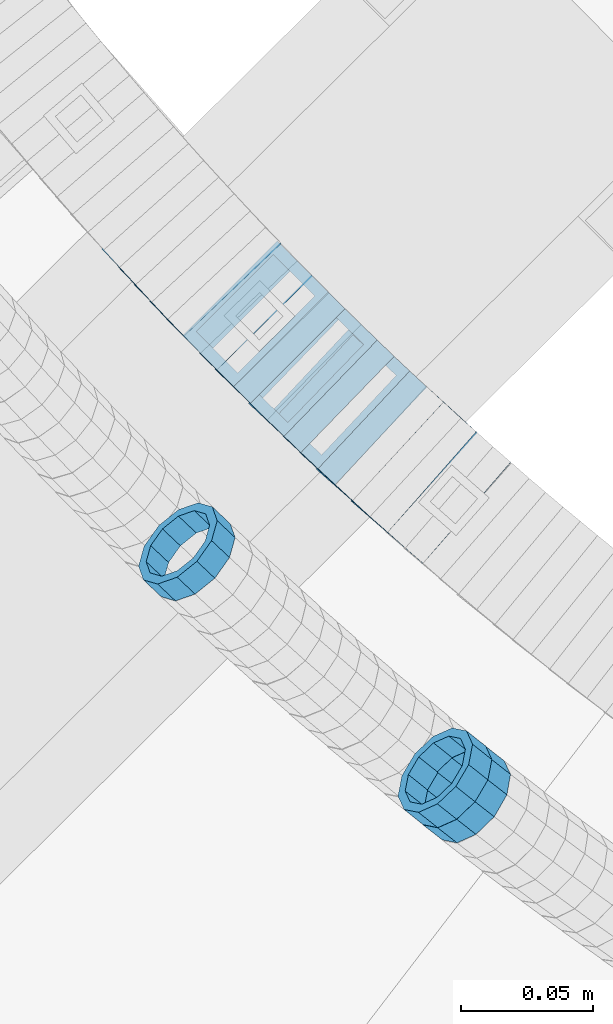
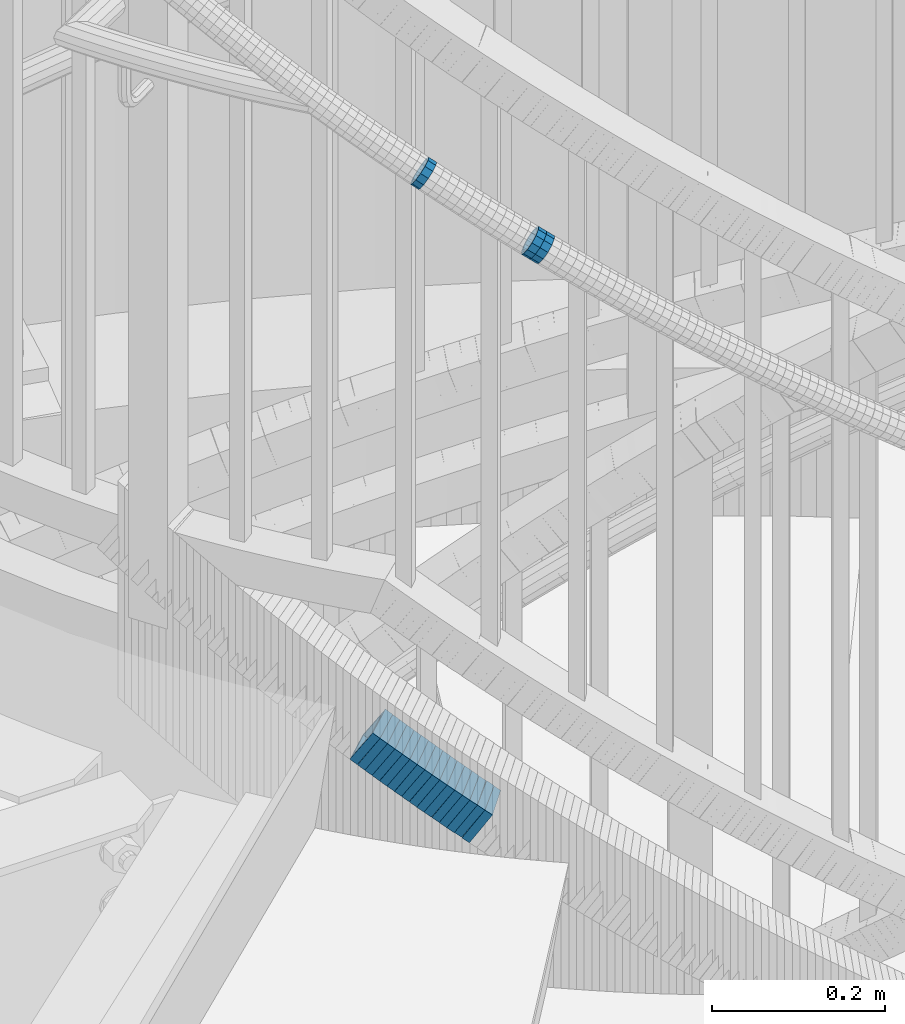
# One storey, part 731 of 975: 19 members.
"""IFC2X3 building model written with IfcOpenShell, lengths in millimetres."""

import ifcopenshell
import ifcopenshell.guid

model = None  # the IFC model being written
_history = None  # IfcOwnerHistory: only IFC2X3 demands one
_inside = {}  # id of a spatial element -> (the spatial element, [elements in it])
_under = {}  # id of a project, library or spatial element -> (it, [spatial elements below it])
_declared = {}  # id of a project -> (the project, [libraries it declares])
_typed = {}  # id of a type object -> (the type object, [elements of that type])
_made_of = {}  # id of a material, layer set ... -> (it, [elements and type objects made of it])


def new_model(schema):
    """Start an empty IFC model of exactly this schema.

    Asked for "IFC4X3", IfcOpenShell would pick the latest addendum, in which some entities
    have other attributes; the version numbers below select the first issue.
    IFC2X3 requires an IfcOwnerHistory on every rooted entity: one is made here for all.
    """
    global model, _history
    if schema == "IFC4X3":
        model = ifcopenshell.file(schema_version=(4, 3, 0, 0))
    else:
        model = ifcopenshell.file(schema=schema)
    _inside.clear()
    _under.clear()
    _declared.clear()
    _typed.clear()
    _made_of.clear()
    _history = None
    if model.schema == "IFC2X3":
        org = make("IfcOrganization", Name="unknown")
        user = make(
            "IfcPersonAndOrganization",
            ThePerson=make("IfcPerson", FamilyName="unknown"),
            TheOrganization=org,
        )
        app = make(
            "IfcApplication",
            ApplicationDeveloper=org,
            Version="unknown",
            ApplicationFullName="unknown",
            ApplicationIdentifier="unknown",
        )
        _history = make(
            "IfcOwnerHistory",
            OwningUser=user,
            OwningApplication=app,
            ChangeAction="ADDED",
            CreationDate=0,
        )
    return model


def make(cls, **values):
    """One entity of the class cls with the attributes given. An attribute that is None is left unset."""
    return model.create_entity(
        cls, **{name: value for name, value in values.items() if value is not None}
    )


def rooted(cls, **values):
    """An entity with a GlobalId (a new one), such as an element, a storey or a relation."""
    return make(cls, GlobalId=ifcopenshell.guid.new(), OwnerHistory=_history, **values)


def si_unit(unit_type, name, prefix=None):
    """IfcSIUnit, for example si_unit("LENGTHUNIT", "METRE", prefix="MILLI")."""
    return make("IfcSIUnit", UnitType=unit_type, Prefix=prefix, Name=name)


def assignment(units):
    """IfcUnitAssignment: the units of a project."""
    return None if units is None else make("IfcUnitAssignment", Units=units)


def point(xyz):
    """IfcCartesianPoint."""
    return None if xyz is None else make("IfcCartesianPoint", Coordinates=xyz)


def direction(xyz):
    """IfcDirection."""
    return None if xyz is None else make("IfcDirection", DirectionRatios=xyz)


def frame(location, z_axis=None, x_axis=None):
    """IfcAxis2Placement3D, a coordinate frame: its origin and axes. An axis left out is left unset."""
    return make(
        "IfcAxis2Placement3D",
        Location=point(location),
        Axis=direction(z_axis),
        RefDirection=direction(x_axis),
    )


def origin_with_axes():
    """The frame at (0, 0, 0) with the z axis (0, 0, 1) and the x axis (1, 0, 0) written out."""
    return frame((0.0, 0.0, 0.0), z_axis=(0.0, 0.0, 1.0), x_axis=(1.0, 0.0, 0.0))


def place(relative_to, where):
    """IfcLocalPlacement: puts the frame where relative to a parent placement (None: the world)."""
    return make(
        "IfcLocalPlacement", PlacementRelTo=relative_to, RelativePlacement=where
    )


def context(
    kind, dimensions, precision=None, world=None, true_north=None, identifier=None
):
    """IfcGeometricRepresentationContext, for example the 3D "Model" context."""
    return make(
        "IfcGeometricRepresentationContext",
        ContextIdentifier=identifier,
        ContextType=kind,
        CoordinateSpaceDimension=dimensions,
        Precision=precision,
        WorldCoordinateSystem=world,
        TrueNorth=true_north,
    )


def subcontext(parent, identifier, kind, view, scale=None):
    """IfcGeometricRepresentationSubContext, for example "Body" below "Model"."""
    return make(
        "IfcGeometricRepresentationSubContext",
        ContextIdentifier=identifier,
        ContextType=kind,
        ParentContext=parent,
        TargetScale=scale,
        TargetView=view,
    )


def project(units=None, contexts=None):
    """IfcProject with its units and contexts."""
    return rooted(
        "IfcProject",
        Name="project",
        RepresentationContexts=contexts,
        UnitsInContext=assignment(units),
    )


def spatial(cls, under=None, at=None, **own):
    """A site, building, storey or space (cls), placed at a placement, below another one or the project."""
    s = rooted(cls, ObjectPlacement=at, **own)
    if under is not None:
        _under.setdefault(under.id(), (under, []))[1].append(s)
    return s


def faces_of(points, faces, orient=None, outer=None):
    """IfcFace entities. A face is a list of loops; a loop is a list of indices into points, from 0.

    orient and outer hold one flag for each loop. By default every Orientation is true, the
    first loop of a face is its IfcFaceOuterBound and the others are IfcFaceBound.
    """
    made = []
    for i, loops in enumerate(faces):
        bounds = []
        for j, loop in enumerate(loops):
            is_outer = j == 0 if outer is None else outer[i][j]
            bounds.append(
                make(
                    "IfcFaceOuterBound" if is_outer else "IfcFaceBound",
                    Bound=make("IfcPolyLoop", Polygon=[points[k] for k in loop]),
                    Orientation=True if orient is None else orient[i][j],
                )
            )
        made.append(make("IfcFace", Bounds=bounds))
    return made


def faceted_brep(points, faces, orient=None, outer=None, voids=None):
    """IfcFacetedBrep: a solid bounded by flat faces; with voids (closed shells), ...WithVoids."""
    shared = [point(p) for p in points]
    hull = make("IfcClosedShell", CfsFaces=faces_of(shared, faces, orient, outer))
    if voids is None:
        return make("IfcFacetedBrep", Outer=hull)
    return make(
        "IfcFacetedBrepWithVoids",
        Outer=hull,
        Voids=[
            make(cls, CfsFaces=faces_of(shared, fs, o, b)) for cls, fs, o, b in voids
        ],
    )


def shape(context_of_items, identifier, shape_type, items):
    """IfcShapeRepresentation: the items that make up one representation, for example the "Body"."""
    return make(
        "IfcShapeRepresentation",
        ContextOfItems=context_of_items,
        RepresentationIdentifier=identifier,
        RepresentationType=shape_type,
        Items=items,
    )


def material(Name=None, Category=None):
    """IfcMaterial."""
    return make("IfcMaterial", Name=Name, Category=Category)


def made_of(thing, what):
    """Note that an element or type object is made of a material, layer set ...; save() writes the relation."""
    if what is not None:
        _made_of.setdefault(what.id(), (what, []))[1].append(thing)
    return thing


def type_object(cls, material=None, **own):
    """A type object (cls), such as IfcWallType, which elements share."""
    return made_of(rooted(cls, **own), material)


def element(
    cls,
    number,
    at=None,
    inside=None,
    cuts=None,
    type_object=None,
    material=None,
    context=None,
    identifier="Body",
    shape_type=None,
    held_by="IfcProductDefinitionShape",
    body=None,
    shapes=None,
    **own,
):
    """One element of the class cls, such as IfcWall. Its Tag is "e" and its number.

    at: its placement. inside: the storey or other place that contains it. cuts: it is an
    opening in that element (IfcRelVoidsElement). A single representation is given by context,
    identifier, shape_type and body (its items); several are given by shapes. held_by: the class
    of the entity that holds the representations. save() writes the other relations.
    """
    e = rooted(cls, Tag="e%d" % number, ObjectPlacement=at, **own)
    if body is not None:
        shapes = [shape(context, identifier, shape_type, body)]
    if shapes is not None:
        e.Representation = make(held_by, Representations=shapes)
    if inside is not None:
        _inside.setdefault(inside.id(), (inside, []))[1].append(e)
    if cuts is not None:
        rooted(
            "IfcRelVoidsElement", RelatingBuildingElement=cuts, RelatedOpeningElement=e
        )
    if type_object is not None:
        _typed.setdefault(type_object.id(), (type_object, []))[1].append(e)
    return made_of(e, material)


def aggregate(whole, parts):
    """IfcRelAggregates: a whole, such as a stair, and the parts it consists of."""
    return rooted("IfcRelAggregates", RelatingObject=whole, RelatedObjects=parts)


def save(model, path):
    """Write the relations noted so far, then the file.

    IfcRelAggregates (storeys below a building ...), IfcRelContainedInSpatialStructure (elements
    in a storey), IfcRelDefinesByType, IfcRelAssociatesMaterial and IfcRelDeclares: one each for
    every whole, place, type object, material and project.
    """
    for whole, parts in _under.values():
        aggregate(whole, parts)
    for where, things in _inside.values():
        rooted(
            "IfcRelContainedInSpatialStructure",
            RelatedElements=things,
            RelatingStructure=where,
        )
    for kind, things in _typed.values():
        rooted("IfcRelDefinesByType", RelatedObjects=things, RelatingType=kind)
    for what, things in _made_of.values():
        rooted("IfcRelAssociatesMaterial", RelatedObjects=things, RelatingMaterial=what)
    for by, libraries in _declared.values():
        rooted("IfcRelDeclares", RelatingContext=by, RelatedDefinitions=libraries)
    model.write(path)


model = new_model("IFC2X3")

# Units and contexts
model_context = context("Model", 3, precision=1e-05, world=origin_with_axes())
body_context = subcontext(model_context, "Body", "Model", "MODEL_VIEW")
ifc_project = project(units=[si_unit("LENGTHUNIT", "METRE", prefix="MILLI"), si_unit("AREAUNIT", "SQUARE_METRE"), si_unit("VOLUMEUNIT", "CUBIC_METRE"), si_unit("MASSUNIT", "GRAM", prefix="KILO"), si_unit("TIMEUNIT", "SECOND"), si_unit("PLANEANGLEUNIT", "RADIAN"), si_unit("SOLIDANGLEUNIT", "STERADIAN"), si_unit("THERMODYNAMICTEMPERATUREUNIT", "DEGREE_CELSIUS"), si_unit("LUMINOUSINTENSITYUNIT", "LUMEN")], contexts=[model_context])

# Site, building, storey
site_placement = place(None, origin_with_axes())
site = spatial("IfcSite", under=ifc_project, at=site_placement, CompositionType="ELEMENT")
building_placement = place(site_placement, origin_with_axes())
building = spatial("IfcBuilding", under=site, at=building_placement, Name="Undefined", CompositionType="ELEMENT")
storey_placement = place(building_placement, origin_with_axes())
storey = spatial("IfcBuildingStorey", under=building, at=storey_placement, Name="Undefined", CompositionType="ELEMENT", Elevation=0.0)

# Members
ifc_material = material()
member_type_1 = type_object("IfcMemberType", PredefinedType="NOTDEFINED")
member_1_placement = place(storey_placement, frame((33819.1274220703, 2241.12991104782, 4815.55457557854), z_axis=(-0.615434495097886, -0.788188037363934, -9.19462763704361e-11), x_axis=(-0.66801209609168, 0.521598486071463, 0.530749337072745)))
element("IfcMember", 1, at=member_1_placement, inside=storey, type_object=member_type_1, material=ifc_material, Name="WALL", context=body_context, shape_type="Brep", body=[
    faceted_brep([(-2.1246523829177e-07, -15.367000000002, 0.0), (-1.83998054126278e-07, -13.3082123799541, 7.68350000000009), (10.9334349588862, -13.3082123799722, 7.68350000000555), (10.9334349588862, -15.3670000000166, 5.45696821063757e-12), (-1.06232619145885e-07, -7.68349999999919, 13.3082123799559), (10.9334349588826, -7.68350000001737, 13.3082123799609), (-3.63797880709171e-12, 3.63797880709171e-12, 15.3670000000002), (10.9334349588862, -1.45519152283669e-11, 15.3670000000043), (1.06225343188271e-07, 7.68350000000646, 13.3082123799559), (10.9334349588898, 7.68349999998827, 13.3082123799591), (1.8399441614747e-07, 13.308212379965, 7.68350000000009), (10.9334349588898, 13.3082123799395, 7.68350000000419), (2.12461600312963e-07, 15.3670000000093, 0.0), (10.9334349588971, 15.3669999999911, 3.63797880709171e-12), (1.8399441614747e-07, 13.308212379965, -7.68350000000009), (10.9334349588935, 13.3082123799431, -7.683499999996), (1.06225343188271e-07, 7.68350000000646, -13.3082123799559), (10.9334349588971, 7.68349999998827, -13.3082123799518), (-3.63797880709171e-12, 3.63797880709171e-12, -15.3670000000002), (10.9334349588971, -1.45519152283669e-11, -15.3669999999961), (-1.06232619145885e-07, -7.68349999999919, -13.3082123799559), (10.9334349588935, -7.68350000001737, -13.3082123799509), (-1.83998054126278e-07, -13.3082123799541, -7.68350000000009), (10.9334349588898, -13.3082123799686, -7.68349999999464), (-2.63386027654633e-07, -19.0500000000029, 0.0), (-2.28097633225843e-07, -16.4977839420972, -9.52499999999964), (10.9334349588898, -16.4977839421117, -9.52499999999372), (10.9334349588898, -19.0500000000211, 5.45696821063757e-12), (-1.31691194837913e-07, -9.52500000000146, -16.4977839420935), (10.9334349588971, -9.52500000001237, -16.4977839420885), (-3.63797880709171e-12, 3.63797880709171e-12, -19.0500000000002), (10.9334349588971, -1.09139364212751e-11, -19.0499999999961), (1.31687556859106e-07, 9.52500000000509, -16.4977839420935), (10.9334349589008, 9.52499999999054, -16.4977839420894), (2.28097633225843e-07, 16.4977839421044, -9.52499999999964), (10.9334349589008, 16.4977839420826, -9.52499999999645), (2.63382389675826e-07, 19.0500000000138, 0.0), (10.9334349588898, 19.0499999999884, 3.18323145620525e-12), (2.28097633225843e-07, 16.4977839421044, 9.52499999999964), (10.9334349588935, 16.497783942079, 9.52500000000282), (1.31687556859106e-07, 9.52500000000509, 16.4977839420935), (10.9334349588826, 9.52499999998327, 16.4977839420976), (-3.63797880709171e-12, 3.63797880709171e-12, 19.0500000000002), (10.9334349588826, -1.81898940354586e-11, 19.0500000000043), (-1.31691194837913e-07, -9.52500000000146, 16.4977839420935), (10.9334349588826, -9.52500000001965, 16.4977839420994), (-2.28097633225843e-07, -16.4977839420972, 9.52499999999964), (10.9334349588826, -16.4977839421117, 9.52500000000646)], [[[0, 1, 2, 3]], [[1, 4, 5, 2]], [[4, 6, 7, 5]], [[6, 8, 9, 7]], [[8, 10, 11, 9]], [[10, 12, 13, 11]], [[12, 14, 15, 13]], [[14, 16, 17, 15]], [[16, 18, 19, 17]], [[18, 20, 21, 19]], [[20, 22, 23, 21]], [[22, 0, 3, 23]], [[24, 25, 26, 27]], [[25, 28, 29, 26]], [[28, 30, 31, 29]], [[30, 32, 33, 31]], [[32, 34, 35, 33]], [[34, 36, 37, 35]], [[36, 38, 39, 37]], [[38, 40, 41, 39]], [[40, 42, 43, 41]], [[42, 44, 45, 43]], [[44, 46, 47, 45]], [[46, 24, 27, 47]], [[29, 31, 33, 35, 37, 39, 41, 43, 45, 47, 27, 26], [5, 7, 9, 11, 13, 15, 17, 19, 21, 23, 3, 2]], [[46, 44, 42, 40, 38, 36, 34, 32, 30, 28, 25, 24], [22, 20, 18, 16, 14, 12, 10, 8, 6, 4, 1, 0]]]),
])
member_2_placement = place(storey_placement, frame((33812.0167979236, 2246.78861505206, 4821.24670998094), z_axis=(-0.622075580833786, -0.782957196614418, 6.82575773680583e-11), x_axis=(-0.668012096091596, 0.530749337072773, 0.521598486071542)))
element("IfcMember", 2, at=member_2_placement, inside=storey, type_object=member_type_1, material=ifc_material, Name="WALL", context=body_context, shape_type="Brep", body=[
    faceted_brep([(-2.1246523829177e-07, -15.367000000002, 0.0), (-1.83998054126278e-07, -13.3082123799541, 7.68350000000009), (10.9334349588862, -13.3082123799722, 7.68350000000555), (10.9334349588862, -15.3670000000166, 5.45696821063757e-12), (-1.06232619145885e-07, -7.68349999999919, 13.3082123799559), (10.9334349588826, -7.68350000001737, 13.3082123799609), (-3.63797880709171e-12, 3.63797880709171e-12, 15.3670000000002), (10.9334349588862, -1.45519152283669e-11, 15.3670000000043), (1.06225343188271e-07, 7.68350000000646, 13.3082123799559), (10.9334349588898, 7.68349999998827, 13.3082123799591), (1.8399441614747e-07, 13.308212379965, 7.68350000000009), (10.9334349588898, 13.3082123799395, 7.68350000000419), (2.12461600312963e-07, 15.3670000000093, 0.0), (10.9334349588971, 15.3669999999911, 3.63797880709171e-12), (1.8399441614747e-07, 13.308212379965, -7.68350000000009), (10.9334349588935, 13.3082123799431, -7.683499999996), (1.06225343188271e-07, 7.68350000000646, -13.3082123799559), (10.9334349588971, 7.68349999998827, -13.3082123799518), (-3.63797880709171e-12, 3.63797880709171e-12, -15.3670000000002), (10.9334349588971, -1.45519152283669e-11, -15.3669999999961), (-1.06232619145885e-07, -7.68349999999919, -13.3082123799559), (10.9334349588935, -7.68350000001737, -13.3082123799509), (-1.83998054126278e-07, -13.3082123799541, -7.68350000000009), (10.9334349588898, -13.3082123799686, -7.68349999999464), (-2.63386027654633e-07, -19.0500000000029, 0.0), (-2.28097633225843e-07, -16.4977839420972, -9.52499999999964), (10.9334349588898, -16.4977839421117, -9.52499999999372), (10.9334349588898, -19.0500000000211, 5.45696821063757e-12), (-1.31691194837913e-07, -9.52500000000146, -16.4977839420935), (10.9334349588971, -9.52500000001237, -16.4977839420885), (-3.63797880709171e-12, 3.63797880709171e-12, -19.0500000000002), (10.9334349588971, -1.09139364212751e-11, -19.0499999999961), (1.31687556859106e-07, 9.52500000000509, -16.4977839420935), (10.9334349589008, 9.52499999999054, -16.4977839420894), (2.28097633225843e-07, 16.4977839421044, -9.52499999999964), (10.9334349589008, 16.4977839420826, -9.52499999999645), (2.63382389675826e-07, 19.0500000000138, 0.0), (10.9334349588898, 19.0499999999884, 3.18323145620525e-12), (2.28097633225843e-07, 16.4977839421044, 9.52499999999964), (10.9334349588935, 16.497783942079, 9.52500000000282), (1.31687556859106e-07, 9.52500000000509, 16.4977839420935), (10.9334349588826, 9.52499999998327, 16.4977839420976), (-3.63797880709171e-12, 3.63797880709171e-12, 19.0500000000002), (10.9334349588826, -1.81898940354586e-11, 19.0500000000043), (-1.31691194837913e-07, -9.52500000000146, 16.4977839420935), (10.9334349588826, -9.52500000001965, 16.4977839420994), (-2.28097633225843e-07, -16.4977839420972, 9.52499999999964), (10.9334349588826, -16.4977839421117, 9.52500000000646)], [[[0, 1, 2, 3]], [[1, 4, 5, 2]], [[4, 6, 7, 5]], [[6, 8, 9, 7]], [[8, 10, 11, 9]], [[10, 12, 13, 11]], [[12, 14, 15, 13]], [[14, 16, 17, 15]], [[16, 18, 19, 17]], [[18, 20, 21, 19]], [[20, 22, 23, 21]], [[22, 0, 3, 23]], [[24, 25, 26, 27]], [[25, 28, 29, 26]], [[28, 30, 31, 29]], [[30, 32, 33, 31]], [[32, 34, 35, 33]], [[34, 36, 37, 35]], [[36, 38, 39, 37]], [[38, 40, 41, 39]], [[40, 42, 43, 41]], [[42, 44, 45, 43]], [[44, 46, 47, 45]], [[46, 24, 27, 47]], [[29, 31, 33, 35, 37, 39, 41, 43, 45, 47, 27, 26], [5, 7, 9, 11, 13, 15, 17, 19, 21, 23, 3, 2]], [[46, 44, 42, 40, 38, 36, 34, 32, 30, 28, 25, 24], [22, 20, 18, 16, 14, 12, 10, 8, 6, 4, 1, 0]]]),
])
member_3_placement = place(storey_placement, frame((33713.8690560859, 2332.20979874917, 4901.53985974245), z_axis=(-0.685364698856158, -0.728199992832881, 5.97719918005167e-12), x_axis=(-0.621555593787518, 0.584993499800019, 0.521009835821907)))
element("IfcMember", 3, at=member_3_placement, inside=storey, type_object=member_type_1, material=ifc_material, Name="WALL", context=body_context, shape_type="Brep", body=[
    faceted_brep([(-2.1246523829177e-07, -15.367000000002, 0.0), (-1.83998054126278e-07, -13.3082123799541, 7.68350000000009), (10.9448618081915, -13.3082123799541, 7.68349999999987), (10.944861808206, -15.3669999999875, -1.81898940354586e-12), (-1.06232619145885e-07, -7.68349999999919, 13.3082123799559), (10.9448618081733, -7.68350000000282, 13.3082123799568), (-3.63797880709171e-12, 3.63797880709171e-12, 15.3670000000002), (10.944861808166, -1.09139364212751e-11, 15.3670000000025), (1.06225343188271e-07, 7.68350000000646, 13.3082123799559), (10.9448618081624, 7.68349999998827, 13.3082123799586), (1.8399441614747e-07, 13.308212379965, 7.68350000000009), (10.9448618081697, 13.3082123799468, 7.68350000000214), (2.12461600312963e-07, 15.3670000000093, 0.0), (10.9448618081842, 15.3669999999984, 2.27373675443232e-13), (1.8399441614747e-07, 13.308212379965, -7.68350000000009), (10.9448618082024, 13.3082123799613, -7.68350000000123), (1.06225343188271e-07, 7.68350000000646, -13.3082123799559), (10.944861808217, 7.68350000001374, -13.3082123799586), (-3.63797880709171e-12, 3.63797880709171e-12, -15.3670000000002), (10.9448618082242, 1.45519152283669e-11, -15.3670000000036), (-1.06232619145885e-07, -7.68349999999919, -13.3082123799559), (10.9448618082279, -7.68349999997736, -13.30821237996), (-1.83998054126278e-07, -13.3082123799541, -7.68350000000009), (10.9448618082242, -13.3082123799322, -7.68350000000351), (-2.63386027654633e-07, -19.0500000000029, 0.0), (-2.28097633225843e-07, -16.4977839420972, -9.52499999999964), (10.9448618082242, -16.4977839420681, -9.52500000000418), (10.9448618082097, -19.0499999999847, -2.50111042987555e-12), (-1.31691194837913e-07, -9.52500000000146, -16.4977839420935), (10.9448618082351, -9.52499999997599, -16.4977839420985), (-3.63797880709171e-12, 3.63797880709171e-12, -19.0500000000002), (10.9448618082315, 2.5465851649642e-11, -19.050000000004), (1.31687556859106e-07, 9.52500000000509, -16.4977839420935), (10.9448618082242, 9.52500000001601, -16.4977839420967), (2.28097633225843e-07, 16.4977839421044, -9.52499999999964), (10.9448618082097, 16.4977839421008, -9.52500000000146), (2.63382389675826e-07, 19.0500000000138, 0.0), (10.9448618081842, 19.049999999992, 1.13686837721616e-12), (2.28097633225843e-07, 16.4977839421044, 9.52499999999964), (10.944861808166, 16.4977839420826, 9.52500000000259), (1.31687556859106e-07, 9.52500000000509, 16.4977839420935), (10.9448618081624, 9.52499999998327, 16.4977839420972), (-3.63797880709171e-12, 3.63797880709171e-12, 19.0500000000002), (10.9448618081587, -1.09139364212751e-11, 19.0500000000031), (-1.31691194837913e-07, -9.52500000000146, 16.4977839420935), (10.9448618081697, -9.52500000000873, 16.4977839420953), (-2.28097633225843e-07, -16.4977839420972, 9.52499999999964), (10.9448618081915, -16.4977839420899, 9.52499999999941)], [[[0, 1, 2, 3]], [[1, 4, 5, 2]], [[4, 6, 7, 5]], [[6, 8, 9, 7]], [[8, 10, 11, 9]], [[10, 12, 13, 11]], [[12, 14, 15, 13]], [[14, 16, 17, 15]], [[16, 18, 19, 17]], [[18, 20, 21, 19]], [[20, 22, 23, 21]], [[22, 0, 3, 23]], [[24, 25, 26, 27]], [[25, 28, 29, 26]], [[28, 30, 31, 29]], [[30, 32, 33, 31]], [[32, 34, 35, 33]], [[34, 36, 37, 35]], [[36, 38, 39, 37]], [[38, 40, 41, 39]], [[40, 42, 43, 41]], [[42, 44, 45, 43]], [[44, 46, 47, 45]], [[46, 24, 27, 47]], [[29, 31, 33, 35, 37, 39, 41, 43, 45, 47, 27, 26], [5, 7, 9, 11, 13, 15, 17, 19, 21, 23, 3, 2]], [[46, 44, 42, 40, 38, 36, 34, 32, 30, 28, 25, 24], [22, 20, 18, 16, 14, 12, 10, 8, 6, 4, 1, 0]]]),
])
member_type_2 = type_object("IfcMemberType", Name="HSS2X2X.188_TUBES", PredefinedType="NOTDEFINED")
member_4_placement = place(storey_placement, frame((33712.3070751934, 2451.15662940741, 4033.60994936357), z_axis=(-0.729187266944916, -0.684314203948306, 0.0), x_axis=(-0.573585986715044, 0.611198182696334, 0.545376839729033)))
element("IfcMember", 4, at=member_4_placement, inside=storey, type_object=member_type_2, material=ifc_material, Name="WALL", ObjectType="HSS2X2X.188_TUBES", context=body_context, shape_type="Brep", body=[
    faceted_brep([(0.0, 20.6374999999753, -20.6375000000298), (0.0, -20.6375000000153, -20.6375000000153), (10.6348483769107, -20.637499999988, -20.6374999999825), (10.6348483768415, 20.6374999999734, -20.6375000001026), (0.0, -20.6374999999825, 20.6375000000335), (10.6348483769852, -20.6374999999589, 20.6375000001462), (0.0, 20.6375000000116, 20.6375000000189), (10.6348483769161, 20.6375000000044, 20.6375000000226), (0.0, 25.3999999999724, -25.4000000000342), (0.0, 25.400000000016, 25.4000000000196), (10.6348483769179, 25.4000000000015, 25.4000000000233), (10.6348483768288, 25.3999999999669, -25.4000000001324), (0.0, -25.399999999976, 25.4000000000378), (10.6348483769998, -25.3999999999505, 25.4000000001688), (0.0, -25.400000000016, -25.4000000000196), (10.6348483769107, -25.3999999999887, -25.3999999999833)], [[[0, 1, 2, 3]], [[1, 4, 5, 2]], [[4, 6, 7, 5]], [[6, 0, 3, 7]], [[8, 9, 10, 11]], [[9, 12, 13, 10]], [[12, 14, 15, 13]], [[14, 8, 11, 15]], [[13, 15, 11, 10], [5, 7, 3, 2]], [[14, 12, 9, 8], [6, 4, 1, 0]]]),
])
member_5_placement = place(storey_placement, frame((33718.45185256, 2444.55281534686, 4027.7533862933), z_axis=(-0.723608232025611, -0.690210929024432, 0.0), x_axis=(-0.582782959908124, 0.610982134903664, 0.53578433391551)))
element("IfcMember", 5, at=member_5_placement, inside=storey, type_object=member_type_2, material=ifc_material, Name="WALL", ObjectType="HSS2X2X.188_TUBES", context=body_context, shape_type="Brep", body=[
    faceted_brep([(0.0, 20.6374999999753, -20.6375000000298), (0.0, -20.6375000000153, -20.6375000000153), (10.6395488625676, -20.6374999999771, -20.6374999999716), (10.6395488625531, 20.6374999999916, -20.6375000000189), (0.0, -20.6374999999825, 20.6375000000335), (10.6395488625731, -20.6374999999844, 20.6375000000153), (0.0, 20.6375000000116, 20.6375000000189), (10.6395488625585, 20.6374999999825, 20.637499999968), (0.0, 25.3999999999724, -25.4000000000342), (0.0, 25.400000000016, 25.4000000000196), (10.6395488625567, 25.3999999999778, 25.3999999999614), (10.6395488625494, 25.3999999999887, -25.4000000000233), (0.0, -25.399999999976, 25.4000000000378), (10.6395488625749, -25.3999999999851, 25.400000000016), (0.0, -25.400000000016, -25.4000000000196), (10.6395488625658, -25.399999999976, -25.3999999999687)], [[[0, 1, 2, 3]], [[1, 4, 5, 2]], [[4, 6, 7, 5]], [[6, 0, 3, 7]], [[8, 9, 10, 11]], [[9, 12, 13, 10]], [[12, 14, 15, 13]], [[14, 8, 11, 15]], [[13, 15, 11, 10], [5, 7, 3, 2]], [[14, 12, 9, 8], [6, 4, 1, 0]]]),
])
member_6_placement = place(storey_placement, frame((33724.3850803941, 2438.2777877808, 4022.10322446153), z_axis=(-0.718240222804792, -0.695795215810889, 0.0), x_axis=(-0.586132836860095, 0.605040347855616, 0.538864059871403)))
element("IfcMember", 6, at=member_6_placement, inside=storey, type_object=member_type_2, material=ifc_material, Name="WALL", ObjectType="HSS2X2X.188_TUBES", context=body_context, shape_type="Brep", body=[
    faceted_brep([(0.0, 20.6374999999753, -20.6375000000298), (0.0, -20.6375000000153, -20.6375000000153), (10.5806427026419, -20.6374999999607, -20.6374999999316), (10.5806427026473, 20.6375000000444, -20.6374999999207), (0.0, -20.6374999999825, 20.6375000000335), (10.5806427025509, -20.6375000000207, 20.6374999999643), (0.0, 20.6375000000116, 20.6375000000189), (10.5806427025545, 20.6374999999862, 20.6374999999716), (0.0, 25.3999999999724, -25.4000000000342), (0.0, 25.400000000016, 25.4000000000196), (10.5806427025436, 25.3999999999796, 25.3999999999614), (10.5806427026582, 25.4000000000542, -25.3999999999105), (0.0, -25.399999999976, 25.4000000000378), (10.5806427025418, -25.4000000000287, 25.3999999999542), (0.0, -25.400000000016, -25.4000000000196), (10.5806427026528, -25.3999999999542, -25.3999999999178)], [[[0, 1, 2, 3]], [[1, 4, 5, 2]], [[4, 6, 7, 5]], [[6, 0, 3, 7]], [[8, 9, 10, 11]], [[9, 12, 13, 10]], [[12, 14, 15, 13]], [[14, 8, 11, 15]], [[13, 15, 11, 10], [5, 7, 3, 2]], [[14, 12, 9, 8], [6, 4, 1, 0]]]),
])
member_7_placement = place(storey_placement, frame((33730.3995083293, 2432.01300851656, 4016.36307719514), z_axis=(-0.712652458853255, -0.701517264855549, 0.0), x_axis=(-0.589299989046761, 0.59865395704757, 0.542530149043141)))
element("IfcMember", 7, at=member_7_placement, inside=storey, type_object=member_type_2, material=ifc_material, Name="WALL", ObjectType="HSS2X2X.188_TUBES", context=body_context, shape_type="Brep", body=[
    faceted_brep([(0.0, 20.6374999999753, -20.6375000000298), (0.0, -20.6375000000153, -20.6375000000153), (10.6906501205649, -20.6374999999844, -20.637499999968), (10.690650120574, 20.6375000000098, -20.6374999999716), (0.0, -20.6374999999825, 20.6375000000335), (10.6906501205467, -20.6374999999844, 20.637500000008), (0.0, 20.6375000000116, 20.6375000000189), (10.6906501205558, 20.637500000008, 20.6375000000007), (0.0, 25.3999999999724, -25.4000000000342), (0.0, 25.400000000016, 25.4000000000196), (10.6906501205522, 25.4000000000087, 25.3999999999978), (10.6906501205813, 25.4000000000124, -25.3999999999651), (0.0, -25.399999999976, 25.4000000000378), (10.6906501205431, -25.3999999999833, 25.4000000000051), (0.0, -25.400000000016, -25.4000000000196), (10.6906501205704, -25.3999999999833, -25.3999999999614)], [[[0, 1, 2, 3]], [[1, 4, 5, 2]], [[4, 6, 7, 5]], [[6, 0, 3, 7]], [[8, 9, 10, 11]], [[9, 12, 13, 10]], [[12, 14, 15, 13]], [[14, 8, 11, 15]], [[13, 15, 11, 10], [5, 7, 3, 2]], [[14, 12, 9, 8], [6, 4, 1, 0]]]),
])
for number, where, z_axis, x_axis, name in (
    (8, (33736.546602821, 2425.71358158495, 4010.6040071192), (-0.707106781186548, -0.707106781186548, 0.0), (-0.595639829263636, 0.595639829263722, 0.538912226238624), "WALL"),
    (9, (33742.846602821, 2419.41358158495, 4004.9040071192), (-0.707106781186548, -0.707106781186548, 0.0), (-0.595639829263636, 0.595639829263722, 0.538912226238624), "WALL"),
):
    element("IfcMember", number, at=place(storey_placement, frame(where, z_axis=z_axis, x_axis=x_axis)), inside=storey, type_object=member_type_2, material=ifc_material, Name=name, ObjectType="HSS2X2X.188_TUBES", context=body_context, shape_type="Brep", body=[
        faceted_brep([(0.0, 20.6374999999753, -20.6375000000298), (0.0, -20.6375000000153, -20.6375000000153), (10.5806427026419, -20.6374999999607, -20.6374999999316), (10.5806427026473, 20.6375000000444, -20.6374999999207), (0.0, -20.6374999999825, 20.6375000000335), (10.5806427025509, -20.6375000000207, 20.6374999999643), (0.0, 20.6375000000116, 20.6375000000189), (10.5806427025545, 20.6374999999862, 20.6374999999716), (0.0, 25.3999999999724, -25.4000000000342), (0.0, 25.400000000016, 25.4000000000196), (10.5806427025436, 25.3999999999796, 25.3999999999614), (10.5806427026582, 25.4000000000542, -25.3999999999105), (0.0, -25.399999999976, 25.4000000000378), (10.5806427025418, -25.4000000000287, 25.3999999999542), (0.0, -25.400000000016, -25.4000000000196), (10.5806427026528, -25.3999999999542, -25.3999999999178)], [[[0, 1, 2, 3]], [[1, 4, 5, 2]], [[4, 6, 7, 5]], [[6, 0, 3, 7]], [[8, 9, 10, 11]], [[9, 12, 13, 10]], [[12, 14, 15, 13]], [[14, 8, 11, 15]], [[13, 15, 11, 10], [5, 7, 3, 2]], [[14, 12, 9, 8], [6, 4, 1, 0]]]),
    ])
member_8_placement = place(storey_placement, frame((33749.0836226885, 2413.12388343331, 3999.1549128678), z_axis=(-0.701517264855551, -0.712652458853252, 0.0), x_axis=(-0.601688743935525, 0.592287356936496, 0.535879036942545)))
element("IfcMember", 10, at=member_8_placement, inside=storey, type_object=member_type_2, material=ifc_material, Name="WALL", ObjectType="HSS2X2X.188_TUBES", context=body_context, shape_type="Brep", body=[
    faceted_brep([(0.0, 20.6374999999753, -20.6375000000298), (0.0, -20.6375000000153, -20.6375000000153), (10.6395488625676, -20.6374999999771, -20.6374999999716), (10.6395488625531, 20.6374999999916, -20.6375000000189), (0.0, -20.6374999999825, 20.6375000000335), (10.6395488625731, -20.6374999999844, 20.6375000000153), (0.0, 20.6375000000116, 20.6375000000189), (10.6395488625585, 20.6374999999825, 20.637499999968), (0.0, 25.3999999999724, -25.4000000000342), (0.0, 25.400000000016, 25.4000000000196), (10.6395488625567, 25.3999999999778, 25.3999999999614), (10.6395488625494, 25.3999999999887, -25.4000000000233), (0.0, -25.399999999976, 25.4000000000378), (10.6395488625749, -25.3999999999851, 25.400000000016), (0.0, -25.400000000016, -25.4000000000196), (10.6395488625658, -25.399999999976, -25.3999999999687)], [[[0, 1, 2, 3]], [[1, 4, 5, 2]], [[4, 6, 7, 5]], [[6, 0, 3, 7]], [[8, 9, 10, 11]], [[9, 12, 13, 10]], [[12, 14, 15, 13]], [[14, 8, 11, 15]], [[13, 15, 11, 10], [5, 7, 3, 2]], [[14, 12, 9, 8], [6, 4, 1, 0]]]),
])
member_9_placement = place(storey_placement, frame((33755.0863143254, 2407.15834216292, 3993.51234156434), z_axis=(-0.69579521581089, -0.718240222804792, 0.0), x_axis=(-0.601954824818981, 0.583143735824549, 0.54552155983585)))
element("IfcMember", 11, at=member_9_placement, inside=storey, type_object=member_type_2, material=ifc_material, Name="WALL", ObjectType="HSS2X2X.188_TUBES", context=body_context, shape_type="Brep", body=[
    faceted_brep([(0.0, 20.6374999999753, -20.6375000000298), (0.0, -20.6375000000153, -20.6375000000153), (10.6348483769107, -20.637499999988, -20.6374999999825), (10.6348483768415, 20.6374999999734, -20.6375000001026), (0.0, -20.6374999999825, 20.6375000000335), (10.6348483769852, -20.6374999999589, 20.6375000001462), (0.0, 20.6375000000116, 20.6375000000189), (10.6348483769161, 20.6375000000044, 20.6375000000226), (0.0, 25.3999999999724, -25.4000000000342), (0.0, 25.400000000016, 25.4000000000196), (10.6348483769179, 25.4000000000015, 25.4000000000233), (10.6348483768288, 25.3999999999669, -25.4000000001324), (0.0, -25.399999999976, 25.4000000000378), (10.6348483769998, -25.3999999999505, 25.4000000001688), (0.0, -25.400000000016, -25.4000000000196), (10.6348483769107, -25.3999999999887, -25.3999999999833)], [[[0, 1, 2, 3]], [[1, 4, 5, 2]], [[4, 6, 7, 5]], [[6, 0, 3, 7]], [[8, 9, 10, 11]], [[9, 12, 13, 10]], [[12, 14, 15, 13]], [[14, 8, 11, 15]], [[13, 15, 11, 10], [5, 7, 3, 2]], [[14, 12, 9, 8], [6, 4, 1, 0]]]),
])
for number, where, z_axis, x_axis, name in (
    (12, (33761.6077691049, 2400.84068284527, 3987.70322446153), (-0.69579521581089, -0.718240222804792, 0.0), (-0.605040347855566, 0.586132836860127, 0.538864059871426), "WALL"),
    (13, (33767.6689925067, 2394.8590851762, 3982.00087833793), (-0.684314203948307, -0.729187266944915, 0.0), (-0.614329411220402, 0.576524524206858, 0.538719637193272), "WALL"),
):
    element("IfcMember", number, at=place(storey_placement, frame(where, z_axis=z_axis, x_axis=x_axis)), inside=storey, type_object=member_type_2, material=ifc_material, Name=name, ObjectType="HSS2X2X.188_TUBES", context=body_context, shape_type="Brep", body=[
        faceted_brep([(0.0, 20.6374999999753, -20.6375000000298), (0.0, -20.6375000000153, -20.6375000000153), (10.5806427026419, -20.6374999999607, -20.6374999999316), (10.5806427026473, 20.6375000000444, -20.6374999999207), (0.0, -20.6374999999825, 20.6375000000335), (10.5806427025509, -20.6375000000207, 20.6374999999643), (0.0, 20.6375000000116, 20.6375000000189), (10.5806427025545, 20.6374999999862, 20.6374999999716), (0.0, 25.3999999999724, -25.4000000000342), (0.0, 25.400000000016, 25.4000000000196), (10.5806427025436, 25.3999999999796, 25.3999999999614), (10.5806427026582, 25.4000000000542, -25.3999999999105), (0.0, -25.399999999976, 25.4000000000378), (10.5806427025418, -25.4000000000287, 25.3999999999542), (0.0, -25.400000000016, -25.4000000000196), (10.5806427026528, -25.3999999999542, -25.3999999999178)], [[[0, 1, 2, 3]], [[1, 4, 5, 2]], [[4, 6, 7, 5]], [[6, 0, 3, 7]], [[8, 9, 10, 11]], [[9, 12, 13, 10]], [[12, 14, 15, 13]], [[14, 8, 11, 15]], [[13, 15, 11, 10], [5, 7, 3, 2]], [[14, 12, 9, 8], [6, 4, 1, 0]]]),
    ])
member_10_placement = place(storey_placement, frame((33774.0456920861, 2388.87479787858, 3976.30994936357), z_axis=(-0.684314203948307, -0.729187266944915, 0.0), x_axis=(-0.611198182696334, 0.573585986715044, 0.545376839729033)))
element("IfcMember", 14, at=member_10_placement, inside=storey, type_object=member_type_2, material=ifc_material, Name="WALL", ObjectType="HSS2X2X.188_TUBES", context=body_context, shape_type="Brep", body=[
    faceted_brep([(0.0, 20.6374999999753, -20.6375000000298), (0.0, -20.6375000000153, -20.6375000000153), (10.6348483769107, -20.637499999988, -20.6374999999825), (10.6348483768415, 20.6374999999734, -20.6375000001026), (0.0, -20.6374999999825, 20.6375000000335), (10.6348483769852, -20.6374999999589, 20.6375000001462), (0.0, 20.6375000000116, 20.6375000000189), (10.6348483769161, 20.6375000000044, 20.6375000000226), (0.0, 25.3999999999724, -25.4000000000342), (0.0, 25.400000000016, 25.4000000000196), (10.6348483769179, 25.4000000000015, 25.4000000000233), (10.6348483768288, 25.3999999999669, -25.4000000001324), (0.0, -25.399999999976, 25.4000000000378), (10.6348483769998, -25.3999999999505, 25.4000000001688), (0.0, -25.400000000016, -25.4000000000196), (10.6348483769107, -25.3999999999887, -25.3999999999833)], [[[0, 1, 2, 3]], [[1, 4, 5, 2]], [[4, 6, 7, 5]], [[6, 0, 3, 7]], [[8, 9, 10, 11]], [[9, 12, 13, 10]], [[12, 14, 15, 13]], [[14, 8, 11, 15]], [[13, 15, 11, 10], [5, 7, 3, 2]], [[14, 12, 9, 8], [6, 4, 1, 0]]]),
])
member_11_placement = place(storey_placement, frame((33780.6147346171, 2382.66078377756, 3970.4503367045), z_axis=(-0.678742109073749, -0.734376708079797, 0.0), x_axis=(-0.620162721767568, 0.573180696785118, 0.535595077799235)))
element("IfcMember", 15, at=member_11_placement, inside=storey, type_object=member_type_2, material=ifc_material, Name="WALL", ObjectType="HSS2X2X.188_TUBES", context=body_context, shape_type="Brep", body=[
    faceted_brep([(0.0, 20.6374999999753, -20.6375000000298), (0.0, -20.6375000000153, -20.6375000000153), (10.6395488625676, -20.6374999999771, -20.6374999999716), (10.6395488625531, 20.6374999999916, -20.6375000000189), (0.0, -20.6374999999825, 20.6375000000335), (10.6395488625731, -20.6374999999844, 20.6375000000153), (0.0, 20.6375000000116, 20.6375000000189), (10.6395488625585, 20.6374999999825, 20.637499999968), (0.0, 25.3999999999724, -25.4000000000342), (0.0, 25.400000000016, 25.4000000000196), (10.6395488625567, 25.3999999999778, 25.3999999999614), (10.6395488625494, 25.3999999999887, -25.4000000000233), (0.0, -25.399999999976, 25.4000000000378), (10.6395488625749, -25.3999999999851, 25.400000000016), (0.0, -25.400000000016, -25.4000000000196), (10.6395488625658, -25.399999999976, -25.3999999999687)], [[[0, 1, 2, 3]], [[1, 4, 5, 2]], [[4, 6, 7, 5]], [[6, 0, 3, 7]], [[8, 9, 10, 11]], [[9, 12, 13, 10]], [[12, 14, 15, 13]], [[14, 8, 11, 15]], [[13, 15, 11, 10], [5, 7, 3, 2]], [[14, 12, 9, 8], [6, 4, 1, 0]]]),
])
for number, where, z_axis, x_axis, name in (
    (16, (33786.9306839468, 2376.76880323942, 3964.79697428563), (-0.672672794195408, -0.739940073214948, 0.0), (-0.623502221313767, 0.566820201285217, 0.538479191270921), "WALL"),
    (17, (33793.1932503559, 2370.96987248755, 3959.09152149674), (-0.660880368115947, -0.750491265131667, 0.0), (-0.632554178015192, 0.557025321013346, 0.538143107012906), "WALL"),
):
    element("IfcMember", number, at=place(storey_placement, frame(where, z_axis=z_axis, x_axis=x_axis)), inside=storey, type_object=member_type_2, material=ifc_material, Name=name, ObjectType="HSS2X2X.188_TUBES", context=body_context, shape_type="Brep", body=[
        faceted_brep([(0.0, 20.6374999999753, -20.6375000000298), (0.0, -20.6375000000153, -20.6375000000153), (10.5948100501191, -20.6375000000335, -20.6375000000844), (10.5948100501555, 20.6374999999971, -20.6375000000116), (0.0, -20.6374999999825, 20.6375000000335), (10.5948100501446, -20.6375000000098, 20.6374999999571), (0.0, 20.6375000000116, 20.6375000000189), (10.5948100501828, 20.6375000000189, 20.6375000000298), (0.0, 25.3999999999724, -25.4000000000342), (0.0, 25.400000000016, 25.4000000000196), (10.5948100501919, 25.4000000000251, 25.4000000000451), (10.5948100501591, 25.3999999999978, -25.4000000000051), (0.0, -25.399999999976, 25.4000000000378), (10.5948100501482, -25.4000000000106, 25.3999999999578), (0.0, -25.400000000016, -25.4000000000196), (10.5948100501118, -25.4000000000378, -25.400000000096)], [[[0, 1, 2, 3]], [[1, 4, 5, 2]], [[4, 6, 7, 5]], [[6, 0, 3, 7]], [[8, 9, 10, 11]], [[9, 12, 13, 10]], [[12, 14, 15, 13]], [[14, 8, 11, 15]], [[13, 15, 11, 10], [5, 7, 3, 2]], [[14, 12, 9, 8], [6, 4, 1, 0]]]),
    ])
member_12_placement = place(storey_placement, frame((33800.1055746598, 2364.98253895487, 3953.40596859345), z_axis=(-0.672672794195408, -0.739940073214948, 0.0), x_axis=(-0.620327053965999, 0.563933684969047, 0.545135895970075)))
element("IfcMember", 18, at=member_12_placement, inside=storey, type_object=member_type_2, material=ifc_material, Name="WALL", ObjectType="HSS2X2X.188_TUBES", context=body_context, shape_type="Brep", body=[
    faceted_brep([(0.0, 20.6374999999753, -20.6375000000298), (0.0, -20.6375000000153, -20.6375000000153), (10.6395488625676, -20.6374999999771, -20.6374999999716), (10.6395488625531, 20.6374999999916, -20.6375000000189), (0.0, -20.6374999999825, 20.6375000000335), (10.6395488625731, -20.6374999999844, 20.6375000000153), (0.0, 20.6375000000116, 20.6375000000189), (10.6395488625585, 20.6374999999825, 20.637499999968), (0.0, 25.3999999999724, -25.4000000000342), (0.0, 25.400000000016, 25.4000000000196), (10.6395488625567, 25.3999999999778, 25.3999999999614), (10.6395488625494, 25.3999999999887, -25.4000000000233), (0.0, -25.399999999976, 25.4000000000378), (10.6395488625749, -25.3999999999851, 25.400000000016), (0.0, -25.400000000016, -25.4000000000196), (10.6395488625658, -25.399999999976, -25.3999999999687)], [[[0, 1, 2, 3]], [[1, 4, 5, 2]], [[4, 6, 7, 5]], [[6, 0, 3, 7]], [[8, 9, 10, 11]], [[9, 12, 13, 10]], [[12, 14, 15, 13]], [[14, 8, 11, 15]], [[13, 15, 11, 10], [5, 7, 3, 2]], [[14, 12, 9, 8], [6, 4, 1, 0]]]),
])
member_13_placement = place(storey_placement, frame((33806.4483887628, 2359.06362224133, 3947.53970037974), z_axis=(-0.655353317243179, -0.755322467280275, 0.0), x_axis=(-0.638167183753152, 0.55370387978581, 0.534934256793031)))
element("IfcMember", 19, at=member_13_placement, inside=storey, type_object=member_type_2, material=ifc_material, Name="WALL", ObjectType="HSS2X2X.188_TUBES", context=body_context, shape_type="Brep", body=[
    faceted_brep([(0.0, 20.6374999999753, -20.6375000000298), (0.0, -20.6375000000153, -20.6375000000153), (10.6625512894789, -20.6374999999625, -20.6374999999389), (10.6625512893879, 20.6374999999789, -20.6375000000371), (0.0, -20.6374999999825, 20.6375000000335), (10.6625512894352, -20.6374999999989, 20.6375000000153), (0.0, 20.6375000000116, 20.6375000000189), (10.6625512893443, 20.6374999999443, 20.6374999999134), (0.0, 25.3999999999724, -25.4000000000342), (0.0, 25.400000000016, 25.4000000000196), (10.6625512893297, 25.3999999999342, 25.3999999998996), (10.6625512893916, 25.399999999976, -25.4000000000415), (0.0, -25.399999999976, 25.4000000000378), (10.6625512894389, -25.399999999996, 25.400000000016), (0.0, -25.400000000016, -25.4000000000196), (10.6625512894971, -25.3999999999523, -25.3999999999214)], [[[0, 1, 2, 3]], [[1, 4, 5, 2]], [[4, 6, 7, 5]], [[6, 0, 3, 7]], [[8, 9, 10, 11]], [[9, 12, 13, 10]], [[12, 14, 15, 13]], [[14, 8, 11, 15]], [[13, 15, 11, 10], [5, 7, 3, 2]], [[14, 12, 9, 8], [6, 4, 1, 0]]]),
])

save(model, "model.ifc")
